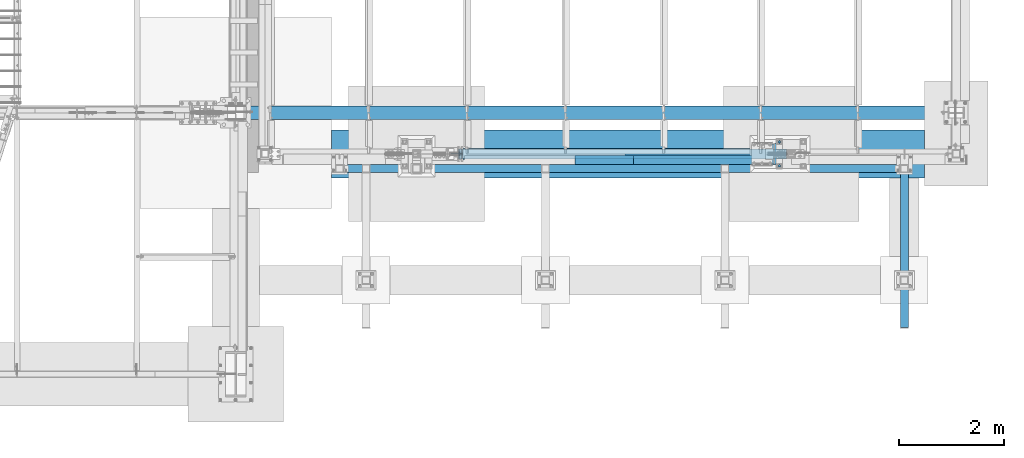
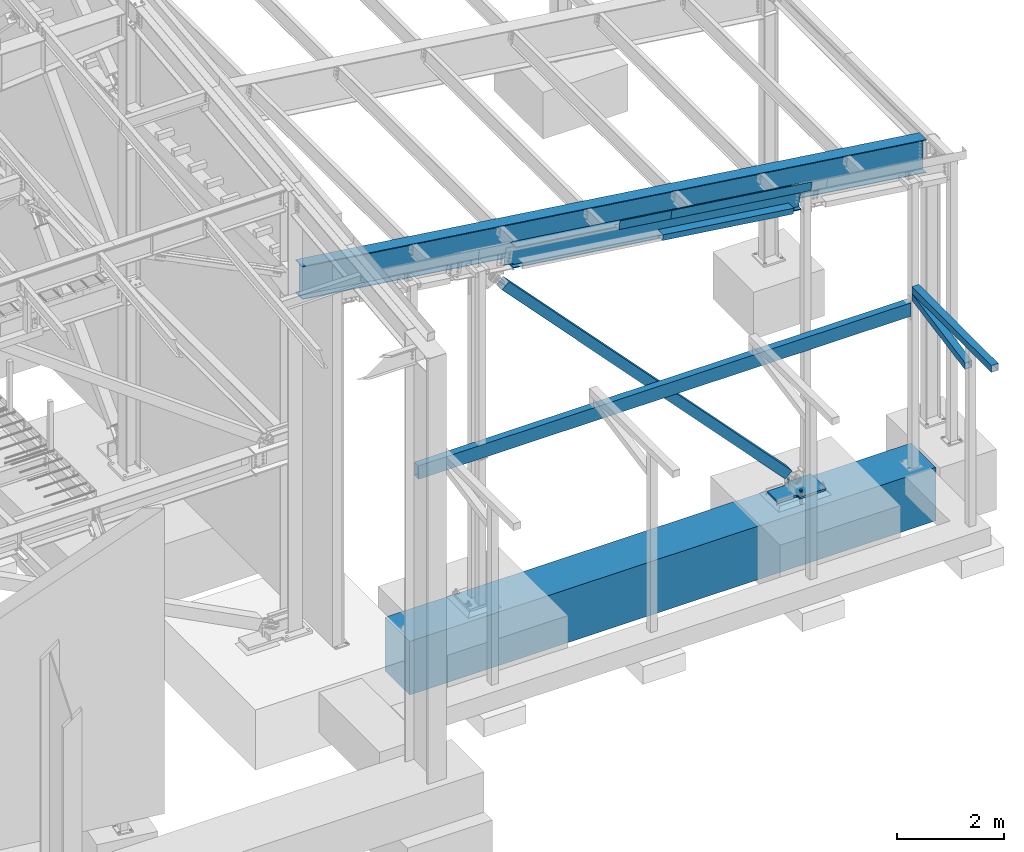
# One storey, part 745 of 1179: 12 beams, 1 member, 9 elements without a shape of their own.
"""IFC2X3 building model written with IfcOpenShell, lengths in millimetres."""

from ifc_helpers import new_model, si_unit, frame, origin_with_axes, place, context, subcontext, project, spatial, faceted_brep, material, type_object, element, aggregate, save


model = new_model("IFC2X3")

# Units and contexts
model_context = context("Model", 3, precision=1e-05, world=origin_with_axes())
body_context = subcontext(model_context, "Body", "Model", "MODEL_VIEW")
ifc_project = project(units=[si_unit("LENGTHUNIT", "METRE", prefix="MILLI"), si_unit("AREAUNIT", "SQUARE_METRE"), si_unit("VOLUMEUNIT", "CUBIC_METRE"), si_unit("MASSUNIT", "GRAM", prefix="KILO"), si_unit("TIMEUNIT", "SECOND"), si_unit("PLANEANGLEUNIT", "RADIAN"), si_unit("SOLIDANGLEUNIT", "STERADIAN"), si_unit("THERMODYNAMICTEMPERATUREUNIT", "DEGREE_CELSIUS"), si_unit("LUMINOUSINTENSITYUNIT", "LUMEN")], contexts=[model_context])

# Site, building, storey
site_placement = place(None, origin_with_axes())
site = spatial("IfcSite", under=ifc_project, at=site_placement, CompositionType="ELEMENT")
building_placement = place(site_placement, origin_with_axes())
building = spatial("IfcBuilding", under=site, at=building_placement, Name="Undefined", CompositionType="ELEMENT")
storey_placement = place(building_placement, origin_with_axes())
storey = spatial("IfcBuildingStorey", under=building, at=storey_placement, Name="Undefined", CompositionType="ELEMENT", Elevation=0.0)

# Assembly, member
assembly_1_placement = place(storey_placement, origin_with_axes())
assembly_1 = element("IfcElementAssembly", 1, at=assembly_1_placement, inside=storey, Name="None", AssemblyPlace="NOTDEFINED", PredefinedType="RIGID_FRAME")
ifc_material_1 = material(Name="STEEL/A992")
member_type = type_object("IfcMemberType", Name="HSS8X8X3/16", PredefinedType="NOTDEFINED")
member_placement = place(assembly_1_placement, frame((34505.6353820187, 4648.2, 214.213859974159), z_axis=(0.0, 1.0, 0.0), x_axis=(-0.687620823867158, 0.0, 0.726069970859731)))
member = element("IfcMember", 2, at=member_placement, type_object=member_type, material=ifc_material_1, Name="None", ObjectType="HSS8X8X3/16", context=body_context, shape_type="Brep", body=[
    faceted_brep([(-3.63797880709171e-12, 96.8374999999978, -96.8375000000015), (-3.63797880709171e-12, -96.8374999999978, -96.8375000000015), (8870.95000004219, -96.8375000065389, -96.8374999999996), (8870.95000004258, 96.837499993042, -96.8374999999996), (-3.63797880709171e-12, -96.8374999999978, 96.8375000000015), (8870.95000004219, -96.8375000065389, 96.8374999999996), (-3.63797880709171e-12, 96.8374999999978, 96.8375000000015), (8870.95000004258, 96.837499993042, 96.8374999999996), (-3.63797880709171e-12, 101.599999999999, -101.599999999999), (-3.63797880709171e-12, 101.599999999999, 101.599999999999), (8870.95000004259, 101.599999993035, 101.6), (8870.95000004259, 101.599999993035, -101.6), (0.0, -101.599999999999, 101.599999999999), (8870.95000004218, -101.600000006532, 101.6), (0.0, -101.599999999999, -101.599999999999), (8870.95000004218, -101.600000006532, -101.6)], [[[0, 1, 2, 3]], [[1, 4, 5, 2]], [[4, 6, 7, 5]], [[6, 0, 3, 7]], [[8, 9, 10, 11]], [[9, 12, 13, 10]], [[12, 14, 15, 13]], [[14, 8, 11, 15]], [[13, 15, 11, 10], [5, 7, 3, 2]], [[14, 12, 9, 8], [6, 4, 1, 0]]]),
])
aggregate(assembly_1, [member])

# Assembly, beams
assembly_2_placement = place(storey_placement, origin_with_axes())
assembly_2 = element("IfcElementAssembly", 3, at=assembly_2_placement, inside=storey, Name="BEAM", AssemblyPlace="NOTDEFINED", PredefinedType="RIGID_FRAME")
ifc_material_2 = material(Name="STEEL/A36")
beam_type_1 = type_object("IfcBeamType", PredefinedType="NOTDEFINED")
beam_1_placement = place(assembly_2_placement, frame((31371.2847418102, 4448.17500001819, 7275.09963214914), z_axis=(0.99100656965293, 0.0, -0.133813223953134), x_axis=(-0.133813222971046, 0.0, -0.991006569785539)))
beam_1 = element("IfcBeam", 4, at=beam_1_placement, type_object=beam_type_1, material=ifc_material_2, Name="BENT_PLATE", context=body_context, shape_type="Brep", body=[
    faceted_brep([(-4.05634636990726e-10, -3.17500000000018, -563.56250000012), (4.0381564758718e-10, -3.17500000000018, 563.562500000124), (4.0381564758718e-10, 3.17500000000018, 563.562500000124), (-4.05634636990726e-10, 3.17500000000018, -563.56250000012), (184.150000000887, 3.17500000000018, 563.562499999825), (184.149999999525, 3.17500000000018, -563.562500000418), (190.499999999527, -3.17500000000018, -563.562500000429), (190.500000000888, -3.17500000000018, 563.562499999818), (184.15000000062, 166.687499998333, 563.562499999745), (184.14999999979, 166.687499997789, -563.562500000498), (190.500000000622, 166.687499998333, 563.562499999734), (190.499999999793, 166.687499997789, -563.562500000513)], [[[0, 1, 2, 3]], [[3, 2, 4, 5]], [[1, 0, 6, 7]], [[5, 4, 8, 9]], [[4, 2, 1, 7, 10, 8]], [[7, 6, 11, 10]], [[6, 0, 3, 5, 9, 11]], [[10, 11, 9, 8]]]),
])
beam_2_placement = place(assembly_2_placement, frame((33440.197407012, 4448.17500002124, 6995.73935111674), z_axis=(0.99100656965293, 0.0, -0.133813223953134), x_axis=(-0.133813222971046, 0.0, -0.991006569785539)))
beam_2 = element("IfcBeam", 5, at=beam_2_placement, type_object=beam_type_1, material=ifc_material_2, Name="BENT_PLATE", context=body_context, shape_type="Brep", body=[
    faceted_brep([(190.49999999687, 166.687500002718, 1262.95848148491), (184.149999996869, 166.687500002718, 1262.95848148493), (184.149999997193, 111.125000983455, 1262.95848148495), (190.499999997195, 111.125000983455, 1262.95848148493), (190.499999997312, 111.125000983468, 1523.99999999997), (184.14999999732, 111.125000983468, 1523.99999999998), (0.0, -3.17499999999927, -1524.0), (6.00266503170133e-10, -3.17499999922438, 1524.00000000052), (6.00266503170133e-10, 3.17500000077416, 1524.00000000052), (0.0, 3.17499999999927, -1524.0), (184.149999997837, 3.17500000000018, 1524.00000000004), (184.149999993959, 3.17500000000018, -1524.00000000062), (190.499999993961, -3.17500000000018, -1524.00000000063), (184.149999994715, 166.687499981327, -1524.00000000071), (190.499999994716, 166.687499981327, -1524.00000000072), (190.499999997839, -3.17500000000018, 1524.00000000003)], [[[0, 1, 2, 3]], [[4, 3, 2, 5]], [[6, 7, 8, 9]], [[9, 8, 10, 11]], [[12, 6, 9, 11, 13, 14]], [[7, 6, 12, 15]], [[10, 8, 7, 15, 4, 5]], [[1, 13, 11, 10, 5, 2]], [[14, 13, 1, 0]], [[15, 12, 14, 0, 3, 4]]]),
])
beam_type_2 = type_object("IfcBeamType", PredefinedType="NOTDEFINED")
beam_3_placement = place(assembly_2_placement, frame((33151.8171362167, 4642.64374999363, 6515.66089269077), z_axis=(-0.99100656978554, 0.0, 0.133813222971043), x_axis=(0.0, -1.0, 0.0)))
beam_3 = element("IfcBeam", 6, at=beam_3_placement, type_object=beam_type_2, material=ifc_material_2, Name="BENT_PLATE", context=body_context, shape_type="Brep", body=[
    faceted_brep([(-2.67391442321241e-10, -3.17500000039036, -1419.22500000031), (1.83717929758132e-10, -3.17499999960455, 1419.2250000003), (0.0, 3.17499999999927, 1419.225), (-1.83717929758132e-10, 3.17499999961183, -1419.22500000032), (197.643749997024, 3.17499999780739, 1419.22500000026), (197.643749997899, 3.17499999702341, -1419.22500000036), (191.293749997899, -3.17500000289692, -1419.22500000035), (191.293749997024, -3.17500000211112, 1419.22500000028), (197.643749997623, -123.825000005674, 1419.22500000047), (197.6437499973, -123.825000008952, -1419.22500000014), (191.2937499973, -117.475000008946, -1419.22500000016), (191.293749997623, -117.475000005672, 1419.22500000046), (27.7812499789825, -123.825000006238, 1419.22500000056), (27.7812499775, -123.825000008312, -1419.22500000006), (27.7812499789843, -117.475000006236, 1419.22500000055), (27.7812499775018, -117.47500000831, -1419.22500000007)], [[[0, 1, 2, 3]], [[3, 2, 4, 5]], [[1, 0, 6, 7]], [[5, 4, 8, 9]], [[7, 6, 10, 11]], [[9, 8, 12, 13]], [[8, 4, 2, 1, 7, 11, 14, 12]], [[11, 10, 15, 14]], [[10, 6, 0, 3, 5, 9, 13, 15]], [[14, 15, 13, 12]]]),
])

# Assembly, beam
assembly_3_placement = place(storey_placement, origin_with_axes())
assembly_3 = element("IfcElementAssembly", 7, at=assembly_3_placement, inside=storey, Name="V_BRACE", AssemblyPlace="NOTDEFINED", PredefinedType="RIGID_FRAME")
ifc_material_3 = material()
beam_type_3 = type_object("IfcBeamType", Name="HSS6X6X1/4", PredefinedType="NOTDEFINED")
beam_4_placement = place(assembly_3_placement, frame((37083.6667960694, 2067.11201111417, 3123.86195697912), z_axis=(-1.0, 0.0, 0.0), x_axis=(0.0, 0.982315302335757, 0.187234203063997)))
beam_4 = element("IfcBeam", 8, at=beam_4_placement, type_object=beam_type_3, material=ifc_material_3, Name="V_BRACE", ObjectType="HSS6X6X1/4", context=body_context, shape_type="Brep", body=[
    faceted_brep([(235.372165385215, 69.8500000000513, -69.8499999999985), (261.999683154555, -69.8499999999422, -69.8499999999985), (2278.86737857677, -69.8499999995015, -69.8499999999985), (2252.23986080743, 69.8500000004919, -69.8499999999985), (261.999683154555, -69.8499999999422, 69.8499999999985), (2278.86737857677, -69.8499999995015, 69.8499999999985), (235.372165385215, 69.8500000000513, 69.8499999999985), (2252.23986080743, 69.8500000004919, 69.8499999999985), (234.161823668427, 76.2000000000507, -76.1999999999971), (234.161823668427, 76.2000000000507, 76.1999999999971), (2251.02951909064, 76.2000000004919, 76.1999999999971), (2251.02951909064, 76.2000000004919, -76.1999999999971), (263.210024871343, -76.1999999999421, 76.1999999999971), (2280.07772029356, -76.199999999501, 76.1999999999971), (263.210024871343, -76.1999999999421, -76.1999999999971), (2280.07772029356, -76.199999999501, -76.1999999999971)], [[[0, 1, 2, 3]], [[1, 4, 5, 2]], [[4, 6, 7, 5]], [[6, 0, 3, 7]], [[8, 9, 10, 11]], [[9, 12, 13, 10]], [[12, 14, 15, 13]], [[14, 8, 11, 15]], [[13, 15, 11, 10], [5, 7, 3, 2]], [[14, 12, 9, 8], [6, 4, 1, 0]]]),
])
aggregate(assembly_3, [beam_4])

assembly_4_placement = place(storey_placement, origin_with_axes())
assembly_4 = element("IfcElementAssembly", 9, at=assembly_4_placement, inside=storey, Name="BEAM", AssemblyPlace="NOTDEFINED", PredefinedType="RIGID_FRAME")
beam_5_placement = place(assembly_4_placement, frame((37084.0, 1320.8, 3702.05), z_axis=(-1.0, 0.0, 0.0), x_axis=(0.0, 1.0, 0.0)))
beam_5 = element("IfcBeam", 10, at=beam_5_placement, type_object=beam_type_3, material=ifc_material_3, Name="BEAM", ObjectType="HSS6X6X1/4", context=body_context, shape_type="Brep", body=[
    faceted_brep([(6.34999999999945, 69.8500000000004, -69.8500000000004), (6.34999999999945, -69.8500000000004, -69.8500000000004), (2971.8, -69.8499999999999, -69.8499999999985), (2971.8, 69.8499999999999, -69.8499999999985), (6.34999999999945, -69.8500000000004, 69.8500000000004), (2971.8, -69.8499999999999, 69.8499999999985), (6.34999999999945, 69.8500000000004, 69.8500000000004), (2971.8, 69.8499999999999, 69.8499999999985), (6.34999999999945, 76.1999999999998, -76.2000000000007), (6.34999999999945, 76.1999999999998, 76.2000000000007), (2971.8, 76.1999999999998, 76.1999999999971), (2971.8, 76.1999999999998, -76.1999999999971), (6.34999999999945, -76.1999999999998, 76.2000000000007), (2971.8, -76.1999999999998, 76.1999999999971), (6.34999999999945, -76.1999999999998, -76.2000000000007), (2971.8, -76.1999999999998, -76.1999999999971)], [[[0, 1, 2, 3]], [[1, 4, 5, 2]], [[4, 6, 7, 5]], [[6, 0, 3, 7]], [[8, 9, 10, 11]], [[9, 12, 13, 10]], [[12, 14, 15, 13]], [[14, 8, 11, 15]], [[13, 15, 11, 10], [5, 7, 3, 2]], [[14, 12, 9, 8], [6, 4, 1, 0]]]),
])
aggregate(assembly_4, [beam_5])

assembly_5_placement = place(storey_placement, origin_with_axes())
assembly_5 = element("IfcElementAssembly", 11, at=assembly_5_placement, inside=storey, Name="BEAM", AssemblyPlace="NOTDEFINED", PredefinedType="RIGID_FRAME")
beam_type_4 = type_object("IfcBeamType", Name="W30X90", PredefinedType="NOTDEFINED")
beam_6_placement = place(assembly_5_placement, frame((24257.6668755384, 5435.6, 7665.35551187371), z_axis=(0.133813223953133, 0.0, 0.991006569652931), x_axis=(0.99100656965293, 0.0, -0.133813223953134)))
beam_6 = element("IfcBeam", 12, at=beam_6_placement, type_object=beam_type_4, material=ifc_material_1, Name="BEAM", ObjectType="W30X90", context=body_context, shape_type="Brep", body=[
    faceted_brep([(267.232803489882, -131.7625, -358.775000000194), (269.376366403885, -131.7625, -374.650000000202), (13823.1084115023, -131.7625, -374.650000003945), (13820.9648485883, -131.7625, -358.77500000394), (267.232803489882, -6.35000000000036, -358.775000000194), (13820.9648485883, -6.35000000000036, -358.77500000394), (170.343759776897, -6.35000000000036, 358.775000000076), (13724.0758048753, -6.35000000000036, 358.774999996333), (170.343759776897, -131.7625, 358.775000000076), (13724.0758048753, -131.7625, 358.774999996333), (168.20019686289, -131.7625, 374.650000000081), (13721.9322419613, -131.7625, 374.649999996338), (168.20019686289, 131.7625, 374.650000000081), (13721.9322419613, 131.7625, 374.649999996338), (170.343759776897, 131.7625, 358.775000000076), (13724.0758048753, 131.7625, 358.774999996333), (170.343759776897, 6.35000000000036, 358.775000000076), (13724.0758048753, 6.35000000000036, 358.774999996333), (267.232803489882, 6.35000000000036, -358.775000000194), (13820.9648485883, 6.35000000000036, -358.77500000394), (267.232803489882, 131.7625, -358.775000000194), (13820.9648485883, 131.7625, -358.77500000394), (269.376366403885, 131.7625, -374.650000000202), (13823.1084115023, 131.7625, -374.650000003945)], [[[0, 1, 2, 3]], [[4, 0, 3, 5]], [[6, 4, 5, 7]], [[8, 6, 7, 9]], [[10, 8, 9, 11]], [[12, 10, 11, 13]], [[14, 12, 13, 15]], [[16, 14, 15, 17]], [[18, 16, 17, 19]], [[20, 18, 19, 21]], [[1, 0, 4, 6, 8, 10, 12, 14, 16, 18, 20, 22]], [[1, 22, 23, 2]], [[19, 17, 15, 13, 11, 9, 7, 5, 3, 2, 23, 21]], [[22, 20, 21, 23]]]),
])
aggregate(assembly_5, [beam_6])

# Beam
beam_type_5 = type_object("IfcBeamType", Name="W18X65", PredefinedType="NOTDEFINED")
beam_7_placement = place(assembly_2_placement, frame((27730.9730115969, 4648.2, 7338.9330624709), z_axis=(0.133813223953133, 0.0, 0.991006569652931), x_axis=(0.99100656965293, 0.0, -0.133813223953134)))
beam_7 = element("IfcBeam", 13, at=beam_7_placement, type_object=beam_type_5, material=ifc_material_1, Name="BEAM", ObjectType="W18X65", context=body_context, shape_type="Brep", body=[
    faceted_brep([(886.589886039543, -96.8374999999996, 233.362499999836), (886.589886039543, 96.8374999999996, 233.362499999836), (875.59130686682, 96.8374999999996, 214.312499999833), (875.59130686682, 5.55624999999964, 214.312499999833), (875.362097632194, 5.55624999999964, 213.915500000912), (875.362097632194, -5.55624999999964, 213.915500000912), (875.59130686682, -5.55624999999964, 214.312499999833), (875.59130686682, -96.8374999999996, 214.312499999833), (918.454304510658, -5.55624999999964, 213.915500000941), (918.454304510658, 5.55624999999964, 213.915500000941), (933.030668707688, 5.55624999999964, 207.055856974068), (933.030668707688, -5.55624999999964, 207.055856974068), (936.886417316728, 5.55624999999964, 203.741552423973), (936.886417316728, -5.55624999999964, 203.741552423973), (938.48784379147, 5.55624999999964, 198.915907883298), (938.48784379147, -5.55624999999964, 198.915907883298), (937.378636710728, 5.55624999999964, 193.953945404695), (937.378636710728, -5.55624999999964, 193.953945404695), (933.874854206038, 5.55624999999964, 190.269529555897), (933.874854206038, -5.55624999999964, 190.269529555897), (928.974866167897, 5.55624999999964, 188.912500000915), (928.974866167897, -5.55624999999964, 188.912500000915), (726.366304510029, 5.55624999999964, 188.912500001154), (726.366304510029, -5.55624999999964, 188.912500001154), (726.366304510018, 5.55624999999964, -188.91249999966), (726.366304510018, -5.55624999999964, -188.91249999966), (929.318866166708, 5.55624999999964, -188.912499999522), (929.318866166708, -5.55624999999964, -188.912499999522), (934.218854204846, 5.55624999999964, -190.269529554496), (934.218854204846, -5.55624999999964, -190.269529554496), (937.722636709521, 5.55624999999964, -193.953945403289), (937.722636709521, -5.55624999999964, -193.953945403289), (938.831843790242, 5.55624999999964, -198.915907881888), (938.831843790242, -5.55624999999964, -198.915907881888), (937.230417315481, 5.55624999999964, -203.741552422565), (937.230417315481, -5.55624999999964, -203.741552422565), (933.374668706427, 5.55624999999964, -207.055856972665), (933.374668706427, -5.55624999999964, -207.055856972665), (918.798304509382, 5.55624999999964, -213.915499999563), (918.798304509382, -5.55624999999964, -213.915499999563), (886.819103278947, 5.55624999999964, -213.915499999526), (886.819103278947, -5.55624999999964, -213.915499999526), (7138.09596883725, 5.55624999999964, -214.312500002041), (7138.09596883725, 96.8374999999996, -214.312500002041), (886.589902047752, 96.8374999999996, -214.312500000317), (886.589902047752, 5.55624999999964, -214.312500000317), (7138.09596883723, 96.8374999999996, -233.362500002047), (7138.09596883723, -96.8374999999996, -233.362500002047), (875.591706970714, -96.8374999999996, -233.362500000319), (875.591706970714, 96.8374999999996, -233.362500000319), (7138.09596883725, -96.8374999999996, -214.312500002041), (886.589902047752, -96.8374999999996, -214.312500000317), (7138.09596883725, -5.55624999999964, -214.312500002041), (886.589902047752, -5.55624999999964, -214.312500000317), (7138.09596883763, 5.55624999999964, 214.312499998105), (7138.09596883763, 96.8374999999996, 214.312499998105), (7138.09596883765, 96.8374999999996, 233.362499998111), (7138.09596883765, -96.8374999999996, 233.362499998111), (7138.09596883763, -96.8374999999996, 214.312499998105), (7138.09596883763, -5.55624999999964, 214.312499998105)], [[[0, 1, 2, 3, 4, 5, 6, 7]], [[8, 9, 10, 11]], [[11, 10, 12, 13]], [[13, 12, 14, 15]], [[15, 14, 16, 17]], [[17, 16, 18, 19]], [[19, 18, 20, 21]], [[21, 20, 22, 23]], [[23, 22, 24, 25]], [[26, 27, 25, 24]], [[27, 26, 28, 29]], [[29, 28, 30, 31]], [[31, 30, 32, 33]], [[33, 32, 34, 35]], [[35, 34, 36, 37]], [[37, 36, 38, 39]], [[39, 38, 40, 41]], [[42, 43, 44, 45]], [[46, 47, 48, 49]], [[47, 50, 51, 48]], [[50, 52, 53, 51]], [[41, 40, 45, 44, 49, 48, 51, 53]], [[43, 46, 49, 44]], [[42, 54, 55, 56, 57, 58, 59, 52, 50, 47, 46, 43]], [[58, 57, 0, 7]], [[59, 58, 7, 6]], [[8, 11, 13, 15, 17, 19, 21, 23, 25, 27, 29, 31, 33, 35, 37, 39, 41, 53, 52, 59, 6, 5]], [[9, 8, 5, 4]], [[54, 42, 45, 40, 38, 36, 34, 32, 30, 28, 26, 24, 22, 20, 18, 16, 14, 12, 10, 9, 4, 3]], [[55, 54, 3, 2]], [[56, 55, 2, 1]], [[57, 56, 1, 0]]]),
])

aggregate(assembly_2, [beam_1, beam_2, beam_3, beam_7])

# Assembly, beam
assembly_6_placement = place(storey_placement, origin_with_axes())
assembly_6 = element("IfcElementAssembly", 14, at=assembly_6_placement, inside=storey, Name="COLUMN", AssemblyPlace="NOTDEFINED", PredefinedType="RIGID_FRAME")
ifc_material_4 = material(Name="STEEL/A572-GR.50")
beam_type_6 = type_object("IfcBeamType", PredefinedType="NOTDEFINED")
beam_8_placement = place(assembly_6_placement, frame((35204.39949646, 4648.2, -253.999999999998), z_axis=(0.0, -1.0, 0.0), x_axis=(-1.0, 0.0, 0.0)))
beam_8 = element("IfcBeam", 15, at=beam_8_placement, type_object=beam_type_6, material=ifc_material_4, context=body_context, shape_type="Brep", body=[
    faceted_brep([(558.799496459957, -25.4, 279.4), (558.799496459957, -25.4, 241.30000076336), (558.799496459957, 25.4, 241.30000076336), (558.799496459957, 25.4, 279.4), (562.666416150307, -25.4, 221.859682691178), (562.666416150307, 25.4, 221.859682691178), (573.678471752217, -25.4, 205.378976818563), (573.678471752217, 25.4, 205.378976818563), (590.159177624831, -25.4, 194.366921216651), (590.159177624831, 25.4, 194.366921216651), (609.599495697017, -25.4, 190.500001526299), (609.599495697017, 25.4, 190.500001526299), (990.599484252925, -25.4, 190.500001526299), (990.599484252925, 25.4, 190.500001526299), (0.0, -25.4, -279.400000000001), (0.0, -25.4, 279.400000000001), (0.0, 25.4, 279.400000000001), (0.0, 25.4, -279.400000000001), (558.799496459957, 25.4, -279.4), (558.799496459957, -25.4, -279.4), (558.799496459957, 25.4, -241.300000763367), (558.799496459957, -25.4, -241.300000763367), (562.666416150307, 25.4, -221.859682691185), (562.666416150307, -25.4, -221.859682691185), (573.678471752217, 25.4, -205.378976818571), (573.678471752217, -25.4, -205.378976818571), (590.159177624831, 25.4, -194.366921216658), (590.159177624831, -25.4, -194.366921216658), (609.599495697017, 25.4, -190.500001526307), (609.599495697017, -25.4, -190.500001526307), (990.599484252925, -25.4, -190.500001526307), (990.599484252925, 25.4, -190.500001526307)], [[[0, 1, 2, 3]], [[4, 5, 2, 1]], [[6, 7, 5, 4]], [[8, 9, 7, 6]], [[10, 11, 9, 8]], [[12, 13, 11, 10]], [[14, 15, 16, 17]], [[14, 17, 18, 19]], [[19, 18, 20, 21]], [[21, 20, 22, 23]], [[23, 22, 24, 25]], [[25, 24, 26, 27]], [[27, 26, 28, 29]], [[30, 29, 28, 31]], [[8, 6, 4, 1, 0, 15, 14, 19, 21, 23, 25, 27, 29, 30, 12, 10]], [[16, 15, 0, 3]], [[31, 28, 26, 24, 22, 20, 18, 17, 16, 3, 2, 5, 7, 9, 11, 13]], [[30, 31, 13, 12]]]),
])
aggregate(assembly_6, [beam_8])

assembly_7_placement = place(storey_placement, origin_with_axes())
assembly_7 = element("IfcElementAssembly", 16, at=assembly_7_placement, inside=storey, Name="BEAM", AssemblyPlace="NOTDEFINED", PredefinedType="RIGID_FRAME")
beam_type_7 = type_object("IfcBeamType", Name="HSS12X6X1/4", PredefinedType="NOTDEFINED")
beam_9_placement = place(assembly_7_placement, frame((26377.9, 4368.8, 3263.9), z_axis=(0.0, 0.0, 1.0), x_axis=(1.0, 0.0, 0.0)))
beam_9 = element("IfcBeam", 17, at=beam_9_placement, type_object=beam_type_7, material=ifc_material_3, Name="BEAM", ObjectType="HSS12X6X1/4", context=body_context, shape_type="Brep", body=[
    faceted_brep([(6.34999999999854, 69.8500000000004, -146.05), (6.34999999999854, -69.8500000000004, -146.05), (10610.85, -69.8500000000004, -146.05), (10610.85, 69.8500000000004, -146.05), (6.34999999999854, -69.8500000000004, 146.05), (10610.85, -69.8500000000004, 146.05), (6.34999999999854, 69.8500000000004, 146.05), (10610.85, 69.8500000000004, 146.05), (6.34999999999854, 76.1999999999998, -152.4), (6.34999999999854, 76.1999999999998, 152.4), (10610.85, 76.1999999999998, 152.4), (10610.85, 76.1999999999998, -152.4), (6.34999999999854, -76.1999999999998, 152.4), (10610.85, -76.1999999999998, 152.4), (6.34999999999854, -76.1999999999998, -152.4), (10610.85, -76.1999999999998, -152.4)], [[[0, 1, 2, 3]], [[1, 4, 5, 2]], [[4, 6, 7, 5]], [[6, 0, 3, 7]], [[8, 9, 10, 11]], [[9, 12, 13, 10]], [[12, 14, 15, 13]], [[14, 8, 11, 15]], [[13, 15, 11, 10], [5, 7, 3, 2]], [[14, 12, 9, 8], [6, 4, 1, 0]]]),
])
aggregate(assembly_7, [beam_9])

# Assembly, beams
assembly_8_placement = place(storey_placement, origin_with_axes())
assembly_8 = element("IfcElementAssembly", 18, at=assembly_8_placement, inside=storey, Name="TEMPLATE", AssemblyPlace="NOTDEFINED", PredefinedType="RIGID_FRAME")
ifc_material_5 = material(Name="STEEL/F1554-GR.55")
beam_type_8 = type_object("IfcBeamType", PredefinedType="NOTDEFINED")
beam_10_placement = place(assembly_8_placement, frame((34696.4, 4876.8, -355.6), z_axis=(0.0, -1.0, 0.0), x_axis=(0.0, 0.0, -1.0)))
beam_10 = element("IfcBeam", 19, at=beam_10_placement, type_object=beam_type_8, material=ifc_material_5, Name="ANCHOR_ROD", context=body_context, shape_type="Brep", body=[
    faceted_brep([(-244.475, -21.2176223927163, 12.25), (-244.475, -12.25, 21.217622392719), (-244.475, 0.0, 24.5), (-244.475, 12.25, 21.217622392719), (-244.475, 21.2176223927163, 12.25), (-244.475, 24.5, 0.0), (-244.475, 21.2176223927163, -12.25), (-244.475, 12.25, -21.217622392719), (-244.475, 0.0, -24.5), (-244.475, -12.25, -21.217622392719), (-244.475, -21.2176223927163, -12.25), (-244.475, -24.5, 0.0), (0.0, 24.5, 0.0), (0.0, 21.2176223927163, -12.25), (0.0, 12.25, -21.217622392719), (0.0, 0.0, -24.5), (0.0, -12.25, -21.217622392719), (0.0, -21.2176223927163, -12.25), (0.0, -24.5, 0.0), (0.0, -21.2176223927163, 12.25), (0.0, -12.25, 21.217622392719), (0.0, 0.0, 24.5), (0.0, 12.25, 21.217622392719), (0.0, 21.2176223927163, 12.25), (0.0, -23.466540125788, 9.72015918207308), (0.0, -17.9605122421417, 17.9605122421381), (0.0, -9.72015918207035, 23.4665401257871), (0.0, 0.0, 25.3999999999996), (0.0, 9.72015918207035, 23.4665401257871), (0.0, 17.9605122421417, 17.9605122421381), (0.0, 23.466540125788, 9.72015918207308), (0.0, 25.4000000000015, 0.0), (0.0, 23.466540125788, -9.72015918207308), (0.0, 17.9605122421417, -17.9605122421381), (0.0, 9.72015918207035, -23.4665401257871), (0.0, 0.0, -25.3999999999996), (0.0, -9.72015918207035, -23.4665401257871), (0.0, -17.9605122421417, -17.9605122421381), (0.0, -23.466540125788, -9.72015918207308), (0.0, -25.4000000000015, 0.0), (946.149999999999, -25.4000000000015, 0.0), (946.149999999999, -23.466540125788, 9.72015918207308), (946.149999999999, -17.9605122421417, 17.9605122421381), (946.149999999999, -9.72015918207035, 23.4665401257871), (946.149999999999, 0.0, 25.3999999999996), (946.149999999999, 9.72015918207035, 23.4665401257871), (946.149999999999, 17.9605122421417, 17.9605122421381), (946.149999999999, 23.466540125788, 9.72015918207308), (946.149999999999, 25.4000000000015, 0.0), (946.149999999999, 23.466540125788, -9.72015918207308), (946.149999999999, 17.9605122421417, -17.9605122421381), (946.149999999999, 9.72015918207035, -23.4665401257871), (946.149999999999, 0.0, -25.3999999999996), (946.149999999999, -9.72015918207035, -23.4665401257871), (946.149999999999, -17.9605122421417, -17.9605122421381), (946.149999999999, -23.466540125788, -9.72015918207308), (946.149999999999, -12.2499999999927, 21.217622392719), (946.149999999999, 7.27595761418343e-12, 24.5), (946.149999999999, 12.2500000000073, 21.217622392719), (946.149999999999, 21.2176223927236, 12.25), (946.149999999999, 24.5000000000073, 0.0), (946.149999999999, 21.2176223927236, -12.25), (946.149999999999, 12.2500000000073, -21.217622392719), (946.149999999999, 7.27595761418343e-12, -24.5), (946.149999999999, -12.2499999999927, -21.217622392719), (946.149999999999, -21.217622392709, -12.25), (946.149999999999, -24.4999999999927, 0.0), (946.149999999999, -21.217622392709, 12.25), (1117.6, -12.2499999999927, -21.217622392719), (1117.6, 7.27595761418343e-12, -24.5), (1117.6, 12.2500000000073, -21.217622392719), (1117.6, 21.2176223927236, -12.25), (1117.6, 24.5000000000073, 0.0), (1117.6, 21.2176223927236, 12.25), (1117.6, 12.2500000000073, 21.217622392719), (1117.6, 7.27595761418343e-12, 24.5), (1117.6, -12.2499999999927, 21.217622392719), (1117.6, -21.217622392709, 12.25), (1117.6, -24.4999999999927, 0.0), (1117.6, -21.217622392709, -12.25)], [[[0, 1, 2, 3, 4, 5, 6, 7, 8, 9, 10, 11]], [[6, 5, 12, 13]], [[7, 6, 13, 14]], [[8, 7, 14, 15]], [[9, 8, 15, 16]], [[10, 9, 16, 17]], [[11, 10, 17, 18]], [[0, 11, 18, 19]], [[1, 0, 19, 20]], [[2, 1, 20, 21]], [[3, 2, 21, 22]], [[4, 3, 22, 23]], [[5, 4, 23, 12]], [[24, 25, 26, 27, 28, 29, 30, 31, 32, 33, 34, 35, 36, 37, 38, 39], [22, 21, 20, 19, 18, 17, 16, 15, 14, 13, 12, 23]], [[24, 39, 40, 41]], [[25, 24, 41, 42]], [[26, 25, 42, 43]], [[27, 26, 43, 44]], [[28, 27, 44, 45]], [[29, 28, 45, 46]], [[30, 29, 46, 47]], [[31, 30, 47, 48]], [[32, 31, 48, 49]], [[33, 32, 49, 50]], [[34, 33, 50, 51]], [[35, 34, 51, 52]], [[36, 35, 52, 53]], [[37, 36, 53, 54]], [[38, 37, 54, 55]], [[39, 38, 55, 40]], [[54, 53, 52, 51, 50, 49, 48, 47, 46, 45, 44, 43, 42, 41, 40, 55], [56, 57, 58, 59, 60, 61, 62, 63, 64, 65, 66, 67]], [[68, 69, 70, 71, 72, 73, 74, 75, 76, 77, 78, 79]], [[76, 75, 57, 56]], [[77, 76, 56, 67]], [[78, 77, 67, 66]], [[79, 78, 66, 65]], [[68, 79, 65, 64]], [[69, 68, 64, 63]], [[70, 69, 63, 62]], [[71, 70, 62, 61]], [[72, 71, 61, 60]], [[73, 72, 60, 59]], [[74, 73, 59, 58]], [[75, 74, 58, 57]]]),
])
beam_11_placement = place(assembly_8_placement, frame((34696.4, 4419.6, -355.6), z_axis=(0.0, -1.0, 0.0), x_axis=(0.0, 0.0, -1.0)))
beam_11 = element("IfcBeam", 20, at=beam_11_placement, type_object=beam_type_8, material=ifc_material_5, Name="ANCHOR_ROD", context=body_context, shape_type="Brep", body=[
    faceted_brep([(-244.475, -21.2176223927163, 12.25), (-244.475, -12.25, 21.217622392719), (-244.475, 0.0, 24.5), (-244.475, 12.25, 21.217622392719), (-244.475, 21.2176223927163, 12.25), (-244.475, 24.5, 0.0), (-244.475, 21.2176223927163, -12.25), (-244.475, 12.25, -21.217622392719), (-244.475, 0.0, -24.5), (-244.475, -12.25, -21.217622392719), (-244.475, -21.2176223927163, -12.25), (-244.475, -24.5, 0.0), (0.0, 24.5, 0.0), (0.0, 21.2176223927163, -12.25), (0.0, 12.25, -21.217622392719), (0.0, 0.0, -24.5), (0.0, -12.25, -21.217622392719), (0.0, -21.2176223927163, -12.25), (0.0, -24.5, 0.0), (0.0, -21.2176223927163, 12.25), (0.0, -12.25, 21.217622392719), (0.0, 0.0, 24.5), (0.0, 12.25, 21.217622392719), (0.0, 21.2176223927163, 12.25), (0.0, -23.466540125788, 9.72015918207308), (0.0, -17.9605122421417, 17.9605122421381), (0.0, -9.72015918207035, 23.4665401257871), (0.0, 0.0, 25.3999999999996), (0.0, 9.72015918207035, 23.4665401257871), (0.0, 17.9605122421417, 17.9605122421381), (0.0, 23.466540125788, 9.72015918207308), (0.0, 25.4000000000015, 0.0), (0.0, 23.466540125788, -9.72015918207308), (0.0, 17.9605122421417, -17.9605122421381), (0.0, 9.72015918207035, -23.4665401257871), (0.0, 0.0, -25.3999999999996), (0.0, -9.72015918207035, -23.4665401257871), (0.0, -17.9605122421417, -17.9605122421381), (0.0, -23.466540125788, -9.72015918207308), (0.0, -25.4000000000015, 0.0), (946.149999999999, -25.4000000000015, 0.0), (946.149999999999, -23.466540125788, 9.72015918207308), (946.149999999999, -17.9605122421417, 17.9605122421381), (946.149999999999, -9.72015918207035, 23.4665401257871), (946.149999999999, 0.0, 25.3999999999996), (946.149999999999, 9.72015918207035, 23.4665401257871), (946.149999999999, 17.9605122421417, 17.9605122421381), (946.149999999999, 23.466540125788, 9.72015918207308), (946.149999999999, 25.4000000000015, 0.0), (946.149999999999, 23.466540125788, -9.72015918207308), (946.149999999999, 17.9605122421417, -17.9605122421381), (946.149999999999, 9.72015918207035, -23.4665401257871), (946.149999999999, 0.0, -25.3999999999996), (946.149999999999, -9.72015918207035, -23.4665401257871), (946.149999999999, -17.9605122421417, -17.9605122421381), (946.149999999999, -23.466540125788, -9.72015918207308), (946.149999999999, -12.2499999999927, 21.217622392719), (946.149999999999, 7.27595761418343e-12, 24.5), (946.149999999999, 12.2500000000073, 21.217622392719), (946.149999999999, 21.2176223927236, 12.25), (946.149999999999, 24.5000000000073, 0.0), (946.149999999999, 21.2176223927236, -12.25), (946.149999999999, 12.2500000000073, -21.217622392719), (946.149999999999, 7.27595761418343e-12, -24.5), (946.149999999999, -12.2499999999927, -21.217622392719), (946.149999999999, -21.217622392709, -12.25), (946.149999999999, -24.4999999999927, 0.0), (946.149999999999, -21.217622392709, 12.25), (1117.6, -12.2499999999927, -21.217622392719), (1117.6, 7.27595761418343e-12, -24.5), (1117.6, 12.2500000000073, -21.217622392719), (1117.6, 21.2176223927236, -12.25), (1117.6, 24.5000000000073, 0.0), (1117.6, 21.2176223927236, 12.25), (1117.6, 12.2500000000073, 21.217622392719), (1117.6, 7.27595761418343e-12, 24.5), (1117.6, -12.2499999999927, 21.217622392719), (1117.6, -21.217622392709, 12.25), (1117.6, -24.4999999999927, 0.0), (1117.6, -21.217622392709, -12.25)], [[[0, 1, 2, 3, 4, 5, 6, 7, 8, 9, 10, 11]], [[6, 5, 12, 13]], [[7, 6, 13, 14]], [[8, 7, 14, 15]], [[9, 8, 15, 16]], [[10, 9, 16, 17]], [[11, 10, 17, 18]], [[0, 11, 18, 19]], [[1, 0, 19, 20]], [[2, 1, 20, 21]], [[3, 2, 21, 22]], [[4, 3, 22, 23]], [[5, 4, 23, 12]], [[24, 25, 26, 27, 28, 29, 30, 31, 32, 33, 34, 35, 36, 37, 38, 39], [22, 21, 20, 19, 18, 17, 16, 15, 14, 13, 12, 23]], [[24, 39, 40, 41]], [[25, 24, 41, 42]], [[26, 25, 42, 43]], [[27, 26, 43, 44]], [[28, 27, 44, 45]], [[29, 28, 45, 46]], [[30, 29, 46, 47]], [[31, 30, 47, 48]], [[32, 31, 48, 49]], [[33, 32, 49, 50]], [[34, 33, 50, 51]], [[35, 34, 51, 52]], [[36, 35, 52, 53]], [[37, 36, 53, 54]], [[38, 37, 54, 55]], [[39, 38, 55, 40]], [[54, 53, 52, 51, 50, 49, 48, 47, 46, 45, 44, 43, 42, 41, 40, 55], [56, 57, 58, 59, 60, 61, 62, 63, 64, 65, 66, 67]], [[68, 69, 70, 71, 72, 73, 74, 75, 76, 77, 78, 79]], [[76, 75, 57, 56]], [[77, 76, 56, 67]], [[78, 77, 67, 66]], [[79, 78, 66, 65]], [[68, 79, 65, 64]], [[69, 68, 64, 63]], [[70, 69, 63, 62]], [[71, 70, 62, 61]], [[72, 71, 61, 60]], [[73, 72, 60, 59]], [[74, 73, 59, 58]], [[75, 74, 58, 57]]]),
])
aggregate(assembly_8, [beam_10, beam_11])

# Assembly, beam
assembly_9_placement = place(storey_placement, origin_with_axes())
assembly_9 = element("IfcElementAssembly", 21, at=assembly_9_placement, inside=storey, Name="GRADE_BEAM", AssemblyPlace="NOTDEFINED", PredefinedType="REINFORCEMENT_UNIT")
ifc_material_6 = material(Name="CONCRETE/5000")
beam_type_9 = type_object("IfcBeamType", PredefinedType="NOTDEFINED")
beam_12_placement = place(assembly_9_placement, frame((26136.6, 4648.2, -1041.4), z_axis=(0.0, 0.0, 1.0), x_axis=(1.0, 0.0, 0.0)))
beam_12 = element("IfcBeam", 22, at=beam_12_placement, type_object=beam_type_9, material=ifc_material_6, Name="GRADE_BEAM", context=body_context, shape_type="Brep", body=[
    faceted_brep([(0.0, 457.2, -609.6), (0.0, 457.2, 609.6), (11328.4, 457.2, 609.6), (11328.4, 457.2, -609.6), (0.0, -457.2, 609.6), (11328.4, -457.2, 609.6), (0.0, -457.2, -609.6), (11328.4, -457.2, -609.6)], [[[0, 1, 2, 3]], [[1, 4, 5, 2]], [[4, 6, 7, 5]], [[6, 0, 3, 7]], [[5, 7, 3, 2]], [[6, 4, 1, 0]]]),
])
aggregate(assembly_9, [beam_12])

save(model, "model.ifc")
